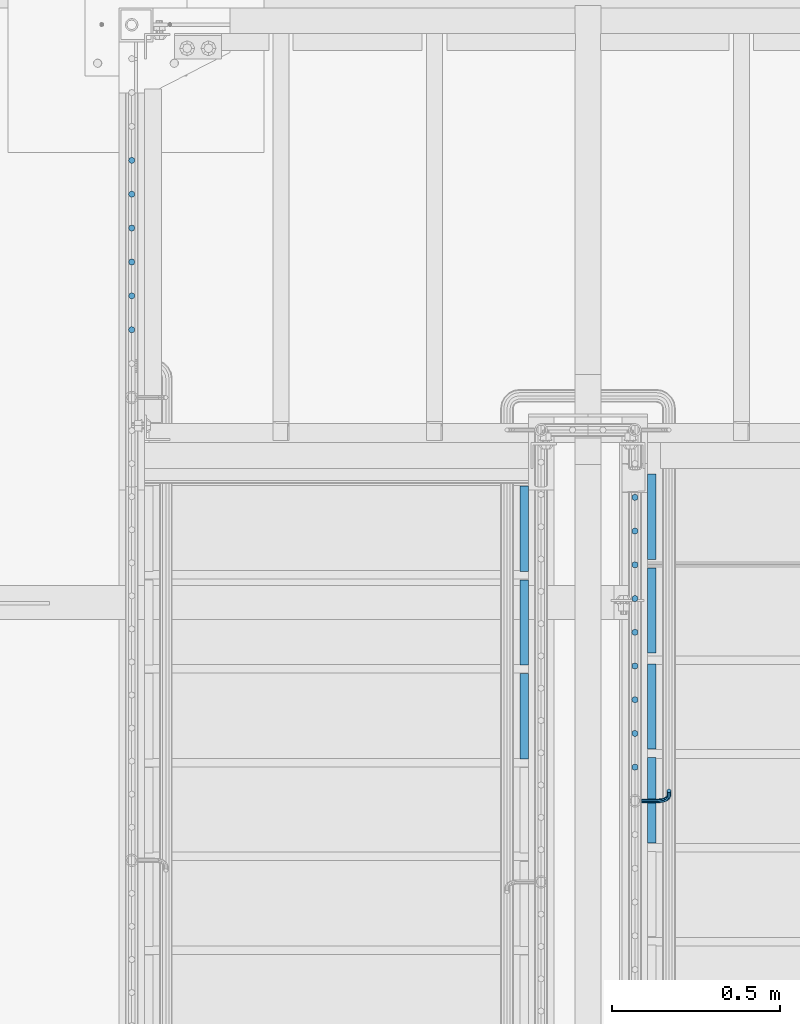
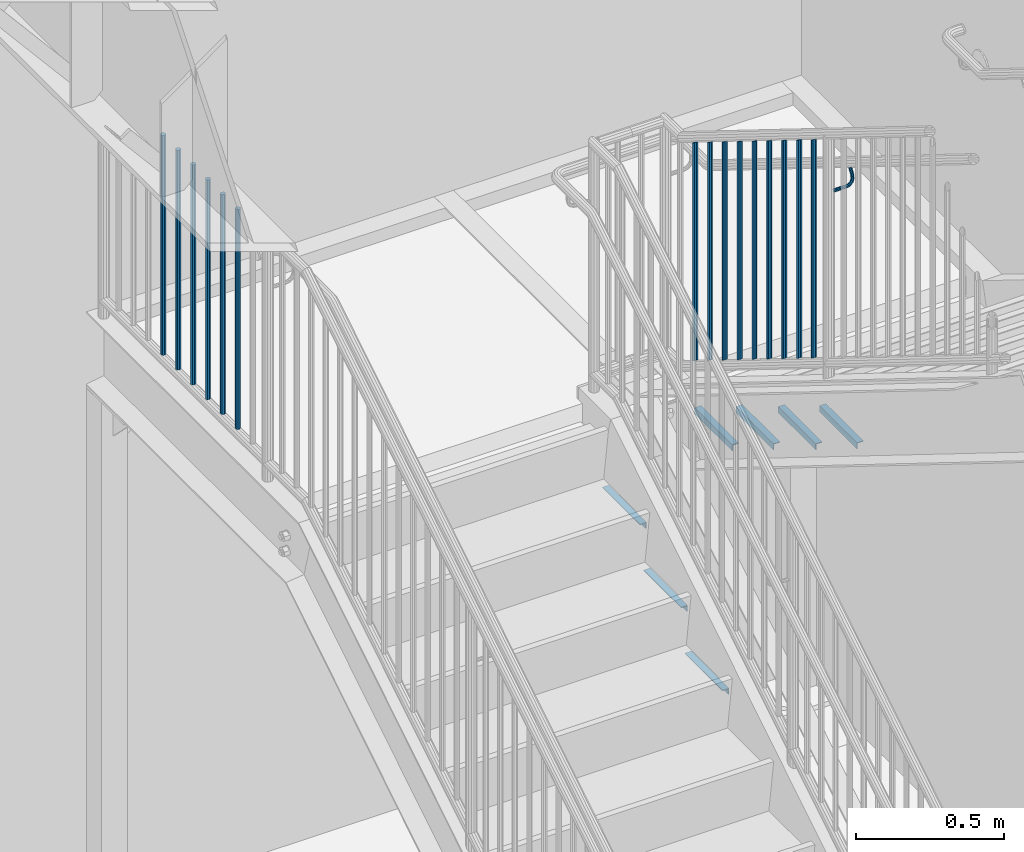
# One storey, part 1272 of 1763: 23 beams, 4 elements without a shape of their own.
"""IFC2X3 building model written with IfcOpenShell, lengths in millimetres."""

from ifc_helpers import new_model, si_unit, frame, origin_with_axes, place, context, subcontext, project, spatial, faceted_brep, material, type_object, element, aggregate, save


model = new_model("IFC2X3")

# Units and contexts
model_context = context("Model", 3, precision=1e-05, world=origin_with_axes())
body_context = subcontext(model_context, "Body", "Model", "MODEL_VIEW")
ifc_project = project(units=[si_unit("LENGTHUNIT", "METRE", prefix="MILLI"), si_unit("AREAUNIT", "SQUARE_METRE"), si_unit("VOLUMEUNIT", "CUBIC_METRE"), si_unit("MASSUNIT", "GRAM", prefix="KILO"), si_unit("TIMEUNIT", "SECOND"), si_unit("PLANEANGLEUNIT", "RADIAN"), si_unit("SOLIDANGLEUNIT", "STERADIAN"), si_unit("THERMODYNAMICTEMPERATUREUNIT", "DEGREE_CELSIUS"), si_unit("LUMINOUSINTENSITYUNIT", "LUMEN")], contexts=[model_context])

# Site, building, storey
site_placement = place(None, origin_with_axes())
site = spatial("IfcSite", under=ifc_project, at=site_placement, CompositionType="ELEMENT")
building_placement = place(site_placement, origin_with_axes())
building = spatial("IfcBuilding", under=site, at=building_placement, Name="Undefined", CompositionType="ELEMENT")
storey_placement = place(building_placement, origin_with_axes())
storey = spatial("IfcBuildingStorey", under=building, at=storey_placement, Name="Undefined", CompositionType="ELEMENT", Elevation=0.0)

# Assembly, beam
assembly_1_placement = place(storey_placement, origin_with_axes())
assembly_1 = element("IfcElementAssembly", 1, at=assembly_1_placement, inside=storey, Name="RAIL", AssemblyPlace="NOTDEFINED", PredefinedType="RIGID_FRAME")
ifc_material = material(Name="STEEL/A36")
beam_type_1 = type_object("IfcBeamType", PredefinedType="NOTDEFINED")
beam_1_placement = place(assembly_1_placement, frame((-85260.8221005485, 34988.5000001836, 4171.79420015574), z_axis=(0.0, -0.849585467029397, 0.527450978018281), x_axis=(1.0, 0.0, 0.0)))
beam_1 = element("IfcBeam", 2, at=beam_1_placement, type_object=beam_type_1, material=ifc_material, Name="RAIL", context=body_context, shape_type="Brep", body=[
    faceted_brep([(0.0, -6.34999999999491, 1.45519152283669e-11), (-1.13686837721616e-13, -4.49012806053361, -4.49012806058454), (50.8000030517578, -4.49012806053452, -4.49012806053361), (50.8000030517578, -6.35000000000036, 0.0), (0.0, 0.0, -6.34999990463257), (50.8000030517578, 0.0, -6.34999999999854), (0.0, 4.49012806054088, -4.49012806053452), (50.8000030517578, 4.49012806053452, -4.49012806053361), (0.0, 6.34999999999491, -2.91038304567337e-11), (50.8000030517578, 6.35000000000036, 0.0), (0.0, 4.49012806054088, 4.49012806053452), (50.8000030517578, 4.49012806053452, 4.49012806053361), (0.0, 0.0, 6.34999990463257), (50.8000030517578, 0.0, 6.34999999999854), (0.0, -4.49012806053361, 4.49012806055543), (50.8000030517578, -4.49012806053452, 4.49012806053361), (65.380241824867, -3.44981018867929, 0.0), (64.6684996473195, -1.73151257071549, 4.49012806053361), (62.9502020293439, 2.4168248427668, 6.34999999999854), (61.2319044113829, 6.5651622562491, 4.49012806053361), (60.5201622338354, 8.2834598742138, 0.0), (61.2319044113829, 6.5651622562491, -4.49012806053361), (62.9502020293439, 2.4168248427668, -6.34999999999854), (64.6684996473195, -1.73151257071549, -4.49012806053361), (76.425643354436, 6.12435969732724, -4.49012806053361), (77.7407714149595, 4.8092316367929, 0.0), (73.2506433544331, 9.29935969732742, -6.34999999999854), (70.0756433544302, 12.4743596973276, -4.49012806053361), (68.7605152938922, 13.7894877578619, 0.0), (70.0756433544302, 12.4743596973276, 4.49012806053361), (73.2506433544331, 9.29935969732742, 6.34999999999854), (76.425643354436, 6.12435969732724, 4.49012806053361), (84.2815156224679, 17.8815034044446, -4.49012806053361), (85.9998132404435, 17.1697612268908, 0.0), (80.1331782089983, 19.5998010224093, -6.34999999999854), (75.9848407955142, 21.3180986403731, -4.49012806053361), (74.2665431775386, 22.0298408179269, 0.0), (75.9848407955142, 21.3180986403731, 4.49012806053361), (80.1331782089983, 19.5998010224093, 6.34999999999854), (84.2815156224679, 17.8815034044446, 4.49012806053361), (87.0401311122987, 31.75, -4.49012806053361), (88.9000030517636, 31.75, 0.0), (82.5500030517578, 31.75, -6.34999999999854), (78.0598749912169, 31.75, -4.49012806053361), (76.200003051752, 31.75, 0.0), (78.0598749912169, 31.75, 4.49012806053361), (82.5500030517578, 31.75, 6.34999999999854), (87.0401311122987, 31.75, 4.49012806053361), (87.0401311122987, 57.1500015258789, -4.49012806053361), (88.9000030517636, 57.1500015258789, 0.0), (82.5500030517578, 57.1500015258789, -6.34999999999854), (78.0598749912169, 57.1500015258789, -4.49012806053361), (76.200003051752, 57.1500015258789, 0.0), (78.0598749912169, 57.1500015258789, 4.49012806053361), (82.5500030517578, 57.1500015258789, 6.34999999999854), (87.0401311122987, 57.1500015258789, 4.49012806053361)], [[[0, 1, 2, 3]], [[1, 4, 5, 2]], [[4, 6, 7, 5]], [[6, 8, 9, 7]], [[8, 10, 11, 9]], [[10, 12, 13, 11]], [[12, 14, 15, 13]], [[14, 0, 3, 15]], [[14, 12, 10, 8, 6, 4, 1, 0]], [[15, 3, 16, 17]], [[13, 15, 17, 18]], [[11, 13, 18, 19]], [[9, 11, 19, 20]], [[7, 9, 20, 21]], [[5, 7, 21, 22]], [[2, 5, 22, 23]], [[3, 2, 23, 16]], [[23, 24, 25, 16]], [[22, 26, 24, 23]], [[21, 27, 26, 22]], [[20, 28, 27, 21]], [[19, 29, 28, 20]], [[18, 30, 29, 19]], [[17, 31, 30, 18]], [[16, 25, 31, 17]], [[24, 32, 33, 25]], [[26, 34, 32, 24]], [[27, 35, 34, 26]], [[28, 36, 35, 27]], [[29, 37, 36, 28]], [[30, 38, 37, 29]], [[31, 39, 38, 30]], [[25, 33, 39, 31]], [[32, 40, 41, 33]], [[34, 42, 40, 32]], [[35, 43, 42, 34]], [[36, 44, 43, 35]], [[37, 45, 44, 36]], [[38, 46, 45, 37]], [[39, 47, 46, 38]], [[33, 41, 47, 39]], [[41, 40, 48, 49]], [[40, 42, 50, 48]], [[42, 43, 51, 50]], [[43, 44, 52, 51]], [[44, 45, 53, 52]], [[45, 46, 54, 53]], [[46, 47, 55, 54]], [[47, 41, 49, 55]], [[50, 51, 52, 53, 54, 55, 49, 48]]]),
])

# Assembly, beams
assembly_2_placement = place(storey_placement, origin_with_axes())
assembly_2 = element("IfcElementAssembly", 3, at=assembly_2_placement, inside=storey, Name="RAIL", AssemblyPlace="NOTDEFINED", PredefinedType="RIGID_FRAME")
beam_type_2 = type_object("IfcBeamType", PredefinedType="NOTDEFINED")
beam_2_placement = place(assembly_2_placement, frame((-86778.5372736927, 36896.2709094602, 3798.8875000151), z_axis=(-1.0, 0.0, 0.0), x_axis=(0.0, 0.0, -1.0)))
beam_2 = element("IfcBeam", 4, at=beam_2_placement, type_object=beam_type_2, material=ifc_material, Name="PICKET", context=body_context, shape_type="Brep", body=[
    faceted_brep([(19.0499999999092, -9.52500000000146, 0.0), (19.0499999999092, -6.73519209080405, -6.73519209079677), (927.099999996084, -6.73519209080405, -6.73519209079677), (927.099999996084, -9.52500000000146, 0.0), (19.0499999999092, 0.0, -9.52499999999418), (927.099999996084, 0.0, -9.52499999999418), (19.0499999999092, 6.73519209080405, -6.73519209079677), (927.099999996084, 6.73519209080405, -6.73519209079677), (19.0499999999092, 9.52500000000146, 0.0), (927.099999996084, 9.52500000000146, 0.0), (19.0499999999092, 6.73519209080405, 6.73519209079677), (927.099999996084, 6.73519209080405, 6.73519209079677), (19.0499999999092, 0.0, 9.52499999999418), (927.099999996084, 0.0, 9.52499999999418), (19.0499999999092, -6.73519209080405, 6.73519209079677), (927.099999996084, -6.73519209080405, 6.73519209079677)], [[[0, 1, 2, 3]], [[1, 4, 5, 2]], [[4, 6, 7, 5]], [[6, 8, 9, 7]], [[8, 10, 11, 9]], [[10, 12, 13, 11]], [[12, 14, 15, 13]], [[14, 0, 3, 15]], [[5, 7, 9, 11, 13, 15, 3, 2]], [[14, 12, 10, 8, 6, 4, 1, 0]]]),
])
beam_3_placement = place(assembly_2_placement, frame((-86778.5372736927, 36795.3636367329, 3798.8875000151), z_axis=(-1.0, 0.0, 0.0), x_axis=(0.0, 0.0, -1.0)))
beam_3 = element("IfcBeam", 5, at=beam_3_placement, type_object=beam_type_2, material=ifc_material, Name="PICKET", context=body_context, shape_type="Brep", body=[
    faceted_brep([(19.0499999999092, -9.52500000000146, 0.0), (19.0499999999092, -6.73519209080405, -6.73519209079677), (927.099999996084, -6.73519209080405, -6.73519209079677), (927.099999996084, -9.52500000000146, 0.0), (19.0499999999092, 0.0, -9.52499999999418), (927.099999996084, 0.0, -9.52499999999418), (19.0499999999092, 6.73519209080405, -6.73519209079677), (927.099999996084, 6.73519209080405, -6.73519209079677), (19.0499999999092, 9.52500000000146, 0.0), (927.099999996084, 9.52500000000146, 0.0), (19.0499999999092, 6.73519209080405, 6.73519209079677), (927.099999996084, 6.73519209080405, 6.73519209079677), (19.0499999999092, 0.0, 9.52499999999418), (927.099999996084, 0.0, 9.52499999999418), (19.0499999999092, -6.73519209080405, 6.73519209079677), (927.099999996084, -6.73519209080405, 6.73519209079677)], [[[0, 1, 2, 3]], [[1, 4, 5, 2]], [[4, 6, 7, 5]], [[6, 8, 9, 7]], [[8, 10, 11, 9]], [[10, 12, 13, 11]], [[12, 14, 15, 13]], [[14, 0, 3, 15]], [[5, 7, 9, 11, 13, 15, 3, 2]], [[14, 12, 10, 8, 6, 4, 1, 0]]]),
])
beam_4_placement = place(assembly_2_placement, frame((-86778.5372736927, 36694.4563640057, 3798.8875000151), z_axis=(-1.0, 0.0, 0.0), x_axis=(0.0, 0.0, -1.0)))
beam_4 = element("IfcBeam", 6, at=beam_4_placement, type_object=beam_type_2, material=ifc_material, Name="PICKET", context=body_context, shape_type="Brep", body=[
    faceted_brep([(19.0499999999092, -9.52500000000146, 0.0), (19.0499999999092, -6.73519209080405, -6.73519209079677), (927.099999996084, -6.73519209080405, -6.73519209079677), (927.099999996084, -9.52500000000146, 0.0), (19.0499999999092, 0.0, -9.52499999999418), (927.099999996084, 0.0, -9.52499999999418), (19.0499999999092, 6.73519209080405, -6.73519209079677), (927.099999996084, 6.73519209080405, -6.73519209079677), (19.0499999999092, 9.52500000000146, 0.0), (927.099999996084, 9.52500000000146, 0.0), (19.0499999999092, 6.73519209080405, 6.73519209079677), (927.099999996084, 6.73519209080405, 6.73519209079677), (19.0499999999092, 0.0, 9.52499999999418), (927.099999996084, 0.0, 9.52499999999418), (19.0499999999092, -6.73519209080405, 6.73519209079677), (927.099999996084, -6.73519209080405, 6.73519209079677)], [[[0, 1, 2, 3]], [[1, 4, 5, 2]], [[4, 6, 7, 5]], [[6, 8, 9, 7]], [[8, 10, 11, 9]], [[10, 12, 13, 11]], [[12, 14, 15, 13]], [[14, 0, 3, 15]], [[5, 7, 9, 11, 13, 15, 3, 2]], [[14, 12, 10, 8, 6, 4, 1, 0]]]),
])
beam_5_placement = place(assembly_2_placement, frame((-86778.5372736927, 36593.5490912784, 3798.8875000151), z_axis=(-1.0, 0.0, 0.0), x_axis=(0.0, 0.0, -1.0)))
beam_5 = element("IfcBeam", 7, at=beam_5_placement, type_object=beam_type_2, material=ifc_material, Name="PICKET", context=body_context, shape_type="Brep", body=[
    faceted_brep([(19.0499999999092, -9.52500000000146, 0.0), (19.0499999999092, -6.73519209080405, -6.73519209079677), (927.099999996084, -6.73519209080405, -6.73519209079677), (927.099999996084, -9.52500000000146, 0.0), (19.0499999999092, 0.0, -9.52499999999418), (927.099999996084, 0.0, -9.52499999999418), (19.0499999999092, 6.73519209080405, -6.73519209079677), (927.099999996084, 6.73519209080405, -6.73519209079677), (19.0499999999092, 9.52500000000146, 0.0), (927.099999996084, 9.52500000000146, 0.0), (19.0499999999092, 6.73519209080405, 6.73519209079677), (927.099999996084, 6.73519209080405, 6.73519209079677), (19.0499999999092, 0.0, 9.52499999999418), (927.099999996084, 0.0, 9.52499999999418), (19.0499999999092, -6.73519209080405, 6.73519209079677), (927.099999996084, -6.73519209080405, 6.73519209079677)], [[[0, 1, 2, 3]], [[1, 4, 5, 2]], [[4, 6, 7, 5]], [[6, 8, 9, 7]], [[8, 10, 11, 9]], [[10, 12, 13, 11]], [[12, 14, 15, 13]], [[14, 0, 3, 15]], [[5, 7, 9, 11, 13, 15, 3, 2]], [[14, 12, 10, 8, 6, 4, 1, 0]]]),
])
beam_6_placement = place(assembly_2_placement, frame((-86778.5372736927, 36492.6418185511, 3798.8875000151), z_axis=(-1.0, 0.0, 0.0), x_axis=(0.0, 0.0, -1.0)))
beam_6 = element("IfcBeam", 8, at=beam_6_placement, type_object=beam_type_2, material=ifc_material, Name="PICKET", context=body_context, shape_type="Brep", body=[
    faceted_brep([(19.0499999999092, -9.52500000000146, 0.0), (19.0499999999092, -6.73519209080405, -6.73519209079677), (927.099999996084, -6.73519209080405, -6.73519209079677), (927.099999996084, -9.52500000000146, 0.0), (19.0499999999092, 0.0, -9.52499999999418), (927.099999996084, 0.0, -9.52499999999418), (19.0499999999092, 6.73519209080405, -6.73519209079677), (927.099999996084, 6.73519209080405, -6.73519209079677), (19.0499999999092, 9.52500000000146, 0.0), (927.099999996084, 9.52500000000146, 0.0), (19.0499999999092, 6.73519209080405, 6.73519209079677), (927.099999996084, 6.73519209080405, 6.73519209079677), (19.0499999999092, 0.0, 9.52499999999418), (927.099999996084, 0.0, 9.52499999999418), (19.0499999999092, -6.73519209080405, 6.73519209079677), (927.099999996084, -6.73519209080405, 6.73519209079677)], [[[0, 1, 2, 3]], [[1, 4, 5, 2]], [[4, 6, 7, 5]], [[6, 8, 9, 7]], [[8, 10, 11, 9]], [[10, 12, 13, 11]], [[12, 14, 15, 13]], [[14, 0, 3, 15]], [[5, 7, 9, 11, 13, 15, 3, 2]], [[14, 12, 10, 8, 6, 4, 1, 0]]]),
])
beam_7_placement = place(assembly_2_placement, frame((-86778.5372736927, 36391.7345458238, 3798.8875000151), z_axis=(-1.0, 0.0, 0.0), x_axis=(0.0, 0.0, -1.0)))
beam_7 = element("IfcBeam", 9, at=beam_7_placement, type_object=beam_type_2, material=ifc_material, Name="PICKET", context=body_context, shape_type="Brep", body=[
    faceted_brep([(19.0499999999092, -9.52500000000146, 0.0), (19.0499999999092, -6.73519209080405, -6.73519209079677), (927.099999996084, -6.73519209080405, -6.73519209079677), (927.099999996084, -9.52500000000146, 0.0), (19.0499999999092, 0.0, -9.52499999999418), (927.099999996084, 0.0, -9.52499999999418), (19.0499999999092, 6.73519209080405, -6.73519209079677), (927.099999996084, 6.73519209080405, -6.73519209079677), (19.0499999999092, 9.52500000000146, 0.0), (927.099999996084, 9.52500000000146, 0.0), (19.0499999999092, 6.73519209080405, 6.73519209079677), (927.099999996084, 6.73519209080405, 6.73519209079677), (19.0499999999092, 0.0, 9.52499999999418), (927.099999996084, 0.0, 9.52499999999418), (19.0499999999092, -6.73519209080405, 6.73519209079677), (927.099999996084, -6.73519209080405, 6.73519209079677)], [[[0, 1, 2, 3]], [[1, 4, 5, 2]], [[4, 6, 7, 5]], [[6, 8, 9, 7]], [[8, 10, 11, 9]], [[10, 12, 13, 11]], [[12, 14, 15, 13]], [[14, 0, 3, 15]], [[5, 7, 9, 11, 13, 15, 3, 2]], [[14, 12, 10, 8, 6, 4, 1, 0]]]),
])
aggregate(assembly_2, [beam_2, beam_3, beam_4, beam_5, beam_6, beam_7])

# Beam
beam_8_placement = place(assembly_1_placement, frame((-85279.8721005486, 35088.9454547462, 4351.52511386684), z_axis=(1.0, 0.0, 0.0), x_axis=(0.0, 0.0, -1.0)))
beam_8 = element("IfcBeam", 10, at=beam_8_placement, type_object=beam_type_2, material=ifc_material, Name="PICKET", context=body_context, shape_type="Brep", body=[
    faceted_brep([(16.5092624764411, -9.52500000000146, 0.0), (18.2412682186596, -6.73519209080041, -6.73519209079677), (919.54586829654, -6.73519209080041, -6.73519209079677), (917.813862554322, -9.52500000000146, 0.0), (22.4226999716293, 0.0, -9.52499999999418), (923.727300049511, 0.0, -9.52499999999418), (26.6041317245999, 6.73519209080041, -6.73519209079677), (927.908731802481, 6.73519209080041, -6.73519209079677), (28.3361374668184, 9.52500000000146, 0.0), (929.6407375447, 9.52500000000146, 0.0), (26.6041317245999, 6.73519209080041, 6.73519209079677), (927.908731802481, 6.73519209080041, 6.73519209079677), (22.4226999716293, 0.0, 9.52499999999418), (923.727300049511, 0.0, 9.52499999999418), (18.2412682186596, -6.73519209080041, 6.73519209079677), (919.54586829654, -6.73519209080041, 6.73519209079677)], [[[0, 1, 2, 3]], [[1, 4, 5, 2]], [[4, 6, 7, 5]], [[6, 8, 9, 7]], [[8, 10, 11, 9]], [[10, 12, 13, 11]], [[12, 14, 15, 13]], [[14, 0, 3, 15]], [[5, 7, 9, 11, 13, 15, 3, 2]], [[14, 12, 10, 8, 6, 4, 1, 0]]]),
])

beam_9_placement = place(assembly_1_placement, frame((-85279.8721005486, 35189.3909093088, 4289.16522754329), z_axis=(1.0, 0.0, 0.0), x_axis=(0.0, 0.0, -1.0)))
beam_9 = element("IfcBeam", 11, at=beam_9_placement, type_object=beam_type_2, material=ifc_material, Name="PICKET", context=body_context, shape_type="Brep", body=[
    faceted_brep([(16.5092624764411, -9.52500000000146, 0.0), (18.2412682186596, -6.73519209080041, -6.73519209079677), (919.54586829654, -6.73519209080041, -6.73519209079677), (917.813862554322, -9.52500000000146, 0.0), (22.4226999716293, 0.0, -9.52499999999418), (923.727300049511, 0.0, -9.52499999999418), (26.6041317245999, 6.73519209080041, -6.73519209079677), (927.908731802481, 6.73519209080041, -6.73519209079677), (28.3361374668184, 9.52500000000146, 0.0), (929.6407375447, 9.52500000000146, 0.0), (26.6041317245999, 6.73519209080041, 6.73519209079677), (927.908731802481, 6.73519209080041, 6.73519209079677), (22.4226999716293, 0.0, 9.52499999999418), (923.727300049511, 0.0, 9.52499999999418), (18.2412682186596, -6.73519209080041, 6.73519209079677), (919.54586829654, -6.73519209080041, 6.73519209079677)], [[[0, 1, 2, 3]], [[1, 4, 5, 2]], [[4, 6, 7, 5]], [[6, 8, 9, 7]], [[8, 10, 11, 9]], [[10, 12, 13, 11]], [[12, 14, 15, 13]], [[14, 0, 3, 15]], [[5, 7, 9, 11, 13, 15, 3, 2]], [[14, 12, 10, 8, 6, 4, 1, 0]]]),
])

beam_10_placement = place(assembly_1_placement, frame((-85279.8721005486, 35289.8363638714, 4226.80534121975), z_axis=(1.0, 0.0, 0.0), x_axis=(0.0, 0.0, -1.0)))
beam_10 = element("IfcBeam", 12, at=beam_10_placement, type_object=beam_type_2, material=ifc_material, Name="PICKET", context=body_context, shape_type="Brep", body=[
    faceted_brep([(16.5092624764411, -9.52500000000146, 0.0), (18.2412682186596, -6.73519209080041, -6.73519209079677), (919.54586829654, -6.73519209080041, -6.73519209079677), (917.813862554322, -9.52500000000146, 0.0), (22.4226999716293, 0.0, -9.52499999999418), (923.727300049511, 0.0, -9.52499999999418), (26.6041317245999, 6.73519209080041, -6.73519209079677), (927.908731802481, 6.73519209080041, -6.73519209079677), (28.3361374668184, 9.52500000000146, 0.0), (929.6407375447, 9.52500000000146, 0.0), (26.6041317245999, 6.73519209080041, 6.73519209079677), (927.908731802481, 6.73519209080041, 6.73519209079677), (22.4226999716293, 0.0, 9.52499999999418), (923.727300049511, 0.0, 9.52499999999418), (18.2412682186596, -6.73519209080041, 6.73519209079677), (919.54586829654, -6.73519209080041, 6.73519209079677)], [[[0, 1, 2, 3]], [[1, 4, 5, 2]], [[4, 6, 7, 5]], [[6, 8, 9, 7]], [[8, 10, 11, 9]], [[10, 12, 13, 11]], [[12, 14, 15, 13]], [[14, 0, 3, 15]], [[5, 7, 9, 11, 13, 15, 3, 2]], [[14, 12, 10, 8, 6, 4, 1, 0]]]),
])

beam_11_placement = place(assembly_1_placement, frame((-85279.8721005486, 35390.281818434, 4164.4454548962), z_axis=(1.0, 0.0, 0.0), x_axis=(0.0, 0.0, -1.0)))
beam_11 = element("IfcBeam", 13, at=beam_11_placement, type_object=beam_type_2, material=ifc_material, Name="PICKET", context=body_context, shape_type="Brep", body=[
    faceted_brep([(16.5092624764411, -9.52500000000146, 0.0), (18.2412682186596, -6.73519209080041, -6.73519209079677), (919.54586829654, -6.73519209080041, -6.73519209079677), (917.813862554322, -9.52500000000146, 0.0), (22.4226999716293, 0.0, -9.52499999999418), (923.727300049511, 0.0, -9.52499999999418), (26.6041317245999, 6.73519209080041, -6.73519209079677), (927.908731802481, 6.73519209080041, -6.73519209079677), (28.3361374668184, 9.52500000000146, 0.0), (929.6407375447, 9.52500000000146, 0.0), (26.6041317245999, 6.73519209080041, 6.73519209079677), (927.908731802481, 6.73519209080041, 6.73519209079677), (22.4226999716293, 0.0, 9.52499999999418), (923.727300049511, 0.0, 9.52499999999418), (18.2412682186596, -6.73519209080041, 6.73519209079677), (919.54586829654, -6.73519209080041, 6.73519209079677)], [[[0, 1, 2, 3]], [[1, 4, 5, 2]], [[4, 6, 7, 5]], [[6, 8, 9, 7]], [[8, 10, 11, 9]], [[10, 12, 13, 11]], [[12, 14, 15, 13]], [[14, 0, 3, 15]], [[5, 7, 9, 11, 13, 15, 3, 2]], [[14, 12, 10, 8, 6, 4, 1, 0]]]),
])

beam_12_placement = place(assembly_1_placement, frame((-85279.8721005486, 35490.7272729966, 4102.08556857265), z_axis=(1.0, 0.0, 0.0), x_axis=(0.0, 0.0, -1.0)))
beam_12 = element("IfcBeam", 14, at=beam_12_placement, type_object=beam_type_2, material=ifc_material, Name="PICKET", context=body_context, shape_type="Brep", body=[
    faceted_brep([(16.5092624764411, -9.52500000000146, 0.0), (18.2412682186596, -6.73519209080041, -6.73519209079677), (919.54586829654, -6.73519209080041, -6.73519209079677), (917.813862554322, -9.52500000000146, 0.0), (22.4226999716293, 0.0, -9.52499999999418), (923.727300049511, 0.0, -9.52499999999418), (26.6041317245999, 6.73519209080041, -6.73519209079677), (927.908731802481, 6.73519209080041, -6.73519209079677), (28.3361374668184, 9.52500000000146, 0.0), (929.6407375447, 9.52500000000146, 0.0), (26.6041317245999, 6.73519209080041, 6.73519209079677), (927.908731802481, 6.73519209080041, 6.73519209079677), (22.4226999716293, 0.0, 9.52499999999418), (923.727300049511, 0.0, 9.52499999999418), (18.2412682186596, -6.73519209080041, 6.73519209079677), (919.54586829654, -6.73519209080041, 6.73519209079677)], [[[0, 1, 2, 3]], [[1, 4, 5, 2]], [[4, 6, 7, 5]], [[6, 8, 9, 7]], [[8, 10, 11, 9]], [[10, 12, 13, 11]], [[12, 14, 15, 13]], [[14, 0, 3, 15]], [[5, 7, 9, 11, 13, 15, 3, 2]], [[14, 12, 10, 8, 6, 4, 1, 0]]]),
])

beam_13_placement = place(assembly_1_placement, frame((-85279.8721005486, 35591.1727275592, 4039.7256822491), z_axis=(1.0, 0.0, 0.0), x_axis=(0.0, 0.0, -1.0)))
beam_13 = element("IfcBeam", 15, at=beam_13_placement, type_object=beam_type_2, material=ifc_material, Name="PICKET", context=body_context, shape_type="Brep", body=[
    faceted_brep([(16.5092624764411, -9.52500000000146, 0.0), (18.2412682186596, -6.73519209080041, -6.73519209079677), (919.54586829654, -6.73519209080041, -6.73519209079677), (917.813862554322, -9.52500000000146, 0.0), (22.4226999716293, 0.0, -9.52499999999418), (923.727300049511, 0.0, -9.52499999999418), (26.6041317245999, 6.73519209080041, -6.73519209079677), (927.908731802481, 6.73519209080041, -6.73519209079677), (28.3361374668184, 9.52500000000146, 0.0), (929.6407375447, 9.52500000000146, 0.0), (26.6041317245999, 6.73519209080041, 6.73519209079677), (927.908731802481, 6.73519209080041, 6.73519209079677), (22.4226999716293, 0.0, 9.52499999999418), (923.727300049511, 0.0, 9.52499999999418), (18.2412682186596, -6.73519209080041, 6.73519209079677), (919.54586829654, -6.73519209080041, 6.73519209079677)], [[[0, 1, 2, 3]], [[1, 4, 5, 2]], [[4, 6, 7, 5]], [[6, 8, 9, 7]], [[8, 10, 11, 9]], [[10, 12, 13, 11]], [[12, 14, 15, 13]], [[14, 0, 3, 15]], [[5, 7, 9, 11, 13, 15, 3, 2]], [[14, 12, 10, 8, 6, 4, 1, 0]]]),
])

beam_14_placement = place(assembly_1_placement, frame((-85279.8721005486, 35691.6181821218, 3977.36579592555), z_axis=(1.0, 0.0, 0.0), x_axis=(0.0, 0.0, -1.0)))
beam_14 = element("IfcBeam", 16, at=beam_14_placement, type_object=beam_type_2, material=ifc_material, Name="PICKET", context=body_context, shape_type="Brep", body=[
    faceted_brep([(16.5092624764411, -9.52500000000146, 0.0), (18.2412682186596, -6.73519209080041, -6.73519209079677), (919.54586829654, -6.73519209080041, -6.73519209079677), (917.813862554322, -9.52500000000146, 0.0), (22.4226999716293, 0.0, -9.52499999999418), (923.727300049511, 0.0, -9.52499999999418), (26.6041317245999, 6.73519209080041, -6.73519209079677), (927.908731802481, 6.73519209080041, -6.73519209079677), (28.3361374668184, 9.52500000000146, 0.0), (929.6407375447, 9.52500000000146, 0.0), (26.6041317245999, 6.73519209080041, 6.73519209079677), (927.908731802481, 6.73519209080041, 6.73519209079677), (22.4226999716293, 0.0, 9.52499999999418), (923.727300049511, 0.0, 9.52499999999418), (18.2412682186596, -6.73519209080041, 6.73519209079677), (919.54586829654, -6.73519209080041, 6.73519209079677)], [[[0, 1, 2, 3]], [[1, 4, 5, 2]], [[4, 6, 7, 5]], [[6, 8, 9, 7]], [[8, 10, 11, 9]], [[10, 12, 13, 11]], [[12, 14, 15, 13]], [[14, 0, 3, 15]], [[5, 7, 9, 11, 13, 15, 3, 2]], [[14, 12, 10, 8, 6, 4, 1, 0]]]),
])

beam_15_placement = place(assembly_1_placement, frame((-85279.8721005486, 35792.0636366845, 3915.005909602), z_axis=(1.0, 0.0, 0.0), x_axis=(0.0, 0.0, -1.0)))
beam_15 = element("IfcBeam", 17, at=beam_15_placement, type_object=beam_type_2, material=ifc_material, Name="PICKET", context=body_context, shape_type="Brep", body=[
    faceted_brep([(16.5092624764411, -9.52500000000146, 0.0), (18.2412682186596, -6.73519209080041, -6.73519209079677), (919.54586829654, -6.73519209080041, -6.73519209079677), (917.813862554322, -9.52500000000146, 0.0), (22.4226999716293, 0.0, -9.52499999999418), (923.727300049511, 0.0, -9.52499999999418), (26.6041317245999, 6.73519209080041, -6.73519209079677), (927.908731802481, 6.73519209080041, -6.73519209079677), (28.3361374668184, 9.52500000000146, 0.0), (929.6407375447, 9.52500000000146, 0.0), (26.6041317245999, 6.73519209080041, 6.73519209079677), (927.908731802481, 6.73519209080041, 6.73519209079677), (22.4226999716293, 0.0, 9.52499999999418), (923.727300049511, 0.0, 9.52499999999418), (18.2412682186596, -6.73519209080041, 6.73519209079677), (919.54586829654, -6.73519209080041, 6.73519209079677)], [[[0, 1, 2, 3]], [[1, 4, 5, 2]], [[4, 6, 7, 5]], [[6, 8, 9, 7]], [[8, 10, 11, 9]], [[10, 12, 13, 11]], [[12, 14, 15, 13]], [[14, 0, 3, 15]], [[5, 7, 9, 11, 13, 15, 3, 2]], [[14, 12, 10, 8, 6, 4, 1, 0]]]),
])

beam_16_placement = place(assembly_1_placement, frame((-85279.8721005486, 35892.5090912471, 3852.64602327846), z_axis=(1.0, 0.0, 0.0), x_axis=(0.0, 0.0, -1.0)))
beam_16 = element("IfcBeam", 18, at=beam_16_placement, type_object=beam_type_2, material=ifc_material, Name="PICKET", context=body_context, shape_type="Brep", body=[
    faceted_brep([(16.5092624764411, -9.52500000000146, 0.0), (18.2412682186596, -6.73519209080041, -6.73519209079677), (919.54586829654, -6.73519209080041, -6.73519209079677), (917.813862554322, -9.52500000000146, 0.0), (22.4226999716293, 0.0, -9.52499999999418), (923.727300049511, 0.0, -9.52499999999418), (26.6041317245999, 6.73519209080041, -6.73519209079677), (927.908731802481, 6.73519209080041, -6.73519209079677), (28.3361374668184, 9.52500000000146, 0.0), (929.6407375447, 9.52500000000146, 0.0), (26.6041317245999, 6.73519209080041, 6.73519209079677), (927.908731802481, 6.73519209080041, 6.73519209079677), (22.4226999716293, 0.0, 9.52499999999418), (923.727300049511, 0.0, 9.52499999999418), (18.2412682186596, -6.73519209080041, 6.73519209079677), (919.54586829654, -6.73519209080041, 6.73519209079677)], [[[0, 1, 2, 3]], [[1, 4, 5, 2]], [[4, 6, 7, 5]], [[6, 8, 9, 7]], [[8, 10, 11, 9]], [[10, 12, 13, 11]], [[12, 14, 15, 13]], [[14, 0, 3, 15]], [[5, 7, 9, 11, 13, 15, 3, 2]], [[14, 12, 10, 8, 6, 4, 1, 0]]]),
])

aggregate(assembly_1, [beam_1, beam_8, beam_9, beam_10, beam_11, beam_12, beam_13, beam_14, beam_15, beam_16])

# Assembly, beams
assembly_3_placement = place(storey_placement, origin_with_axes())
assembly_3 = element("IfcElementAssembly", 19, at=assembly_3_placement, inside=storey, Name="STRINGER", AssemblyPlace="NOTDEFINED", PredefinedType="RIGID_FRAME")
beam_type_3 = type_object("IfcBeamType", Name="L1X1X1/8", PredefinedType="NOTDEFINED")
beam_17_placement = place(assembly_3_placement, frame((-85229.1372739139, 35708.1024604921, 2665.41250020067), z_axis=(1.0, 0.0, 0.0), x_axis=(0.0, 1.0, 0.0)))
beam_17 = element("IfcBeam", 20, at=beam_17_placement, type_object=beam_type_3, material=ifc_material, Name="ANGLE", ObjectType="L1X1X1/8", context=body_context, shape_type="Brep", body=[
    faceted_brep([(3.93434019839663e-12, 12.6999999999978, -12.6999998092651), (-1.31614667686587e-12, 12.6999999999978, 12.6999998092651), (254.0, 12.69999981, 12.6999998099927), (254.0, 12.69999981, -12.6999998099927), (-1.06936913171421e-12, 9.52499999999854, 12.699999332428), (254.0, 9.52499985799977, 12.6999998099927), (0.0, 9.52499985799977, -9.52499985799659), (254.0, 9.52499985799977, -9.52499985799659), (0.0, -12.69999981, -9.52499985799659), (254.0, -12.69999981, -9.52499985799659), (0.0, -12.69999981, -12.6999998099927), (254.0, -12.69999981, -12.6999998099927)], [[[0, 1, 2, 3]], [[1, 4, 5, 2]], [[4, 6, 7, 5]], [[6, 8, 9, 7]], [[8, 10, 11, 9]], [[10, 0, 3, 11]], [[5, 7, 9, 11, 3, 2]], [[10, 8, 6, 4, 1, 0]]]),
])
beam_18_placement = place(assembly_3_placement, frame((-85229.1372739139, 35428.7024604084, 2838.87333353424), z_axis=(1.0, 0.0, 0.0), x_axis=(0.0, 1.0, 0.0)))
beam_18 = element("IfcBeam", 21, at=beam_18_placement, type_object=beam_type_3, material=ifc_material, Name="ANGLE", ObjectType="L1X1X1/8", context=body_context, shape_type="Brep", body=[
    faceted_brep([(3.93434019839663e-12, 12.6999999999978, -12.6999998092651), (-1.31614667686587e-12, 12.6999999999978, 12.6999998092651), (254.0, 12.69999981, 12.6999998099927), (254.0, 12.69999981, -12.6999998099927), (-1.06936913171421e-12, 9.52499999999854, 12.699999332428), (254.0, 9.52499985799977, 12.6999998099927), (0.0, 9.52499985799977, -9.52499985799659), (254.0, 9.52499985799977, -9.52499985799659), (0.0, -12.69999981, -9.52499985799659), (254.0, -12.69999981, -9.52499985799659), (0.0, -12.69999981, -12.6999998099927), (254.0, -12.69999981, -12.6999998099927)], [[[0, 1, 2, 3]], [[1, 4, 5, 2]], [[4, 6, 7, 5]], [[6, 8, 9, 7]], [[8, 10, 11, 9]], [[10, 0, 3, 11]], [[5, 7, 9, 11, 3, 2]], [[10, 8, 6, 4, 1, 0]]]),
])

assembly_4_placement = place(storey_placement, origin_with_axes())
assembly_4 = element("IfcElementAssembly", 22, at=assembly_4_placement, inside=storey, Name="STRINGER", AssemblyPlace="NOTDEFINED", PredefinedType="RIGID_FRAME")
beam_19_placement = place(assembly_4_placement, frame((-85610.137273544, 35926.2511407179, 2492.03482161915), z_axis=(-1.0, 0.0, 0.0), x_axis=(0.0, -1.0, 0.0)))
beam_19 = element("IfcBeam", 23, at=beam_19_placement, type_object=beam_type_3, material=ifc_material, Name="ANGLE", ObjectType="L1X1X1/8", context=body_context, shape_type="Brep", body=[
    faceted_brep([(3.93434019839663e-12, 12.6999999999978, -12.6999998092651), (-1.31614667686587e-12, 12.6999999999978, 12.6999998092651), (254.0, 12.69999981, 12.6999998099927), (254.0, 12.69999981, -12.6999998099927), (-1.06936913171421e-12, 9.52499999999854, 12.699999332428), (254.0, 9.52499985799977, 12.6999998099927), (0.0, 9.52499985799977, -9.52499985799659), (254.0, 9.52499985799977, -9.52499985799659), (0.0, -12.69999981, -9.52499985799659), (254.0, -12.69999981, -9.52499985799659), (0.0, -12.69999981, -12.6999998099927), (254.0, -12.69999981, -12.6999998099927)], [[[0, 1, 2, 3]], [[1, 4, 5, 2]], [[4, 6, 7, 5]], [[6, 8, 9, 7]], [[8, 10, 11, 9]], [[10, 0, 3, 11]], [[5, 7, 9, 11, 3, 2]], [[10, 8, 6, 4, 1, 0]]]),
])
beam_20_placement = place(assembly_4_placement, frame((-85610.137273544, 35646.8511407179, 2318.65714304772), z_axis=(-1.0, 0.0, 0.0), x_axis=(0.0, -1.0, 0.0)))
beam_20 = element("IfcBeam", 24, at=beam_20_placement, type_object=beam_type_3, material=ifc_material, Name="ANGLE", ObjectType="L1X1X1/8", context=body_context, shape_type="Brep", body=[
    faceted_brep([(3.93434019839663e-12, 12.6999999999978, -12.6999998092651), (-1.31614667686587e-12, 12.6999999999978, 12.6999998092651), (254.0, 12.69999981, 12.6999998099927), (254.0, 12.69999981, -12.6999998099927), (-1.06936913171421e-12, 9.52499999999854, 12.699999332428), (254.0, 9.52499985799977, 12.6999998099927), (0.0, 9.52499985799977, -9.52499985799659), (254.0, 9.52499985799977, -9.52499985799659), (0.0, -12.69999981, -9.52499985799659), (254.0, -12.69999981, -9.52499985799659), (0.0, -12.69999981, -12.6999998099927), (254.0, -12.69999981, -12.6999998099927)], [[[0, 1, 2, 3]], [[1, 4, 5, 2]], [[4, 6, 7, 5]], [[6, 8, 9, 7]], [[8, 10, 11, 9]], [[10, 0, 3, 11]], [[5, 7, 9, 11, 3, 2]], [[10, 8, 6, 4, 1, 0]]]),
])
beam_21_placement = place(assembly_4_placement, frame((-85610.137273544, 35367.4511407179, 2145.27946447629), z_axis=(-1.0, 0.0, 0.0), x_axis=(0.0, -1.0, 0.0)))
beam_21 = element("IfcBeam", 25, at=beam_21_placement, type_object=beam_type_3, material=ifc_material, Name="ANGLE", ObjectType="L1X1X1/8", context=body_context, shape_type="Brep", body=[
    faceted_brep([(3.93434019839663e-12, 12.6999999999978, -12.6999998092651), (-1.31614667686587e-12, 12.6999999999978, 12.6999998092651), (254.0, 12.69999981, 12.6999998099927), (254.0, 12.69999981, -12.6999998099927), (-1.06936913171421e-12, 9.52499999999854, 12.699999332428), (254.0, 9.52499985799977, 12.6999998099927), (0.0, 9.52499985799977, -9.52499985799659), (254.0, 9.52499985799977, -9.52499985799659), (0.0, -12.69999981, -9.52499985799659), (254.0, -12.69999981, -9.52499985799659), (0.0, -12.69999981, -12.6999998099927), (254.0, -12.69999981, -12.6999998099927)], [[[0, 1, 2, 3]], [[1, 4, 5, 2]], [[4, 6, 7, 5]], [[6, 8, 9, 7]], [[8, 10, 11, 9]], [[10, 0, 3, 11]], [[5, 7, 9, 11, 3, 2]], [[10, 8, 6, 4, 1, 0]]]),
])
aggregate(assembly_4, [beam_19, beam_20, beam_21])

# Beam
beam_22_placement = place(assembly_3_placement, frame((-85229.072101503, 34863.5524602555, 3185.79500020325), z_axis=(1.0, 0.0, 0.0), x_axis=(0.0, 1.0, 0.0)))
beam_22 = element("IfcBeam", 26, at=beam_22_placement, type_object=beam_type_3, material=ifc_material, Name="ANGLE", ObjectType="L1X1X1/8", context=body_context, shape_type="Brep", body=[
    faceted_brep([(3.93434019839663e-12, 12.6999999999978, -12.6999998092651), (-1.31614667686587e-12, 12.6999999999978, 12.6999998092651), (254.0, 12.69999981, 12.6999998099927), (254.0, 12.69999981, -12.6999998099927), (-1.06936913171421e-12, 9.52499999999854, 12.699999332428), (254.0, 9.52499985799977, 12.6999998099927), (0.0, 9.52499985799977, -9.52499985799659), (254.0, 9.52499985799977, -9.52499985799659), (0.0, -12.69999981, -9.52499985799659), (254.0, -12.69999981, -9.52499985799659), (0.0, -12.69999981, -12.6999998099927), (254.0, -12.69999981, -12.6999998099927)], [[[0, 1, 2, 3]], [[1, 4, 5, 2]], [[4, 6, 7, 5]], [[6, 8, 9, 7]], [[8, 10, 11, 9]], [[10, 0, 3, 11]], [[5, 7, 9, 11, 3, 2]], [[10, 8, 6, 4, 1, 0]]]),
])

beam_23_placement = place(assembly_3_placement, frame((-85229.072101503, 35142.9524603394, 3012.33416686991), z_axis=(1.0, 0.0, 0.0), x_axis=(0.0, 1.0, 0.0)))
beam_23 = element("IfcBeam", 27, at=beam_23_placement, type_object=beam_type_3, material=ifc_material, Name="ANGLE", ObjectType="L1X1X1/8", context=body_context, shape_type="Brep", body=[
    faceted_brep([(3.93434019839663e-12, 12.6999999999978, -12.6999998092651), (-1.31614667686587e-12, 12.6999999999978, 12.6999998092651), (254.0, 12.69999981, 12.6999998099927), (254.0, 12.69999981, -12.6999998099927), (-1.06936913171421e-12, 9.52499999999854, 12.699999332428), (254.0, 9.52499985799977, 12.6999998099927), (0.0, 9.52499985799977, -9.52499985799659), (254.0, 9.52499985799977, -9.52499985799659), (0.0, -12.69999981, -9.52499985799659), (254.0, -12.69999981, -9.52499985799659), (0.0, -12.69999981, -12.6999998099927), (254.0, -12.69999981, -12.6999998099927)], [[[0, 1, 2, 3]], [[1, 4, 5, 2]], [[4, 6, 7, 5]], [[6, 8, 9, 7]], [[8, 10, 11, 9]], [[10, 0, 3, 11]], [[5, 7, 9, 11, 3, 2]], [[10, 8, 6, 4, 1, 0]]]),
])

aggregate(assembly_3, [beam_17, beam_18, beam_22, beam_23])

save(model, "model.ifc")
